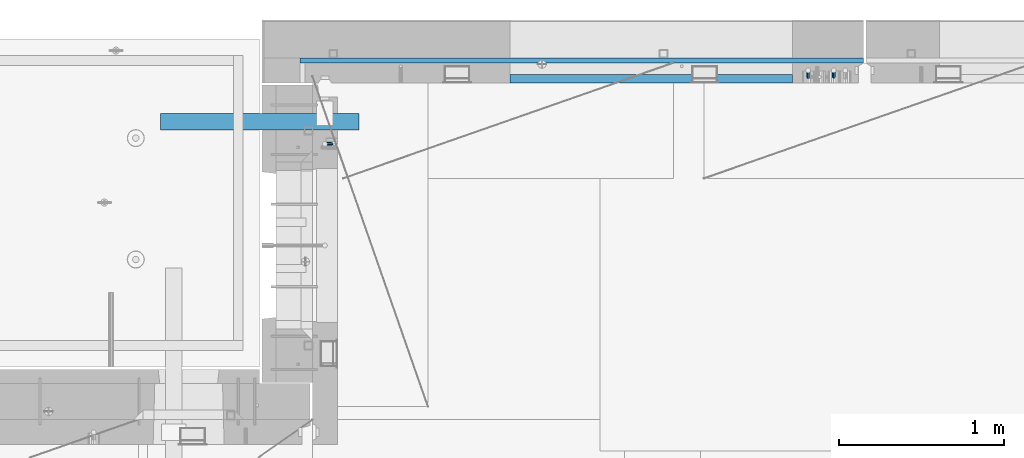
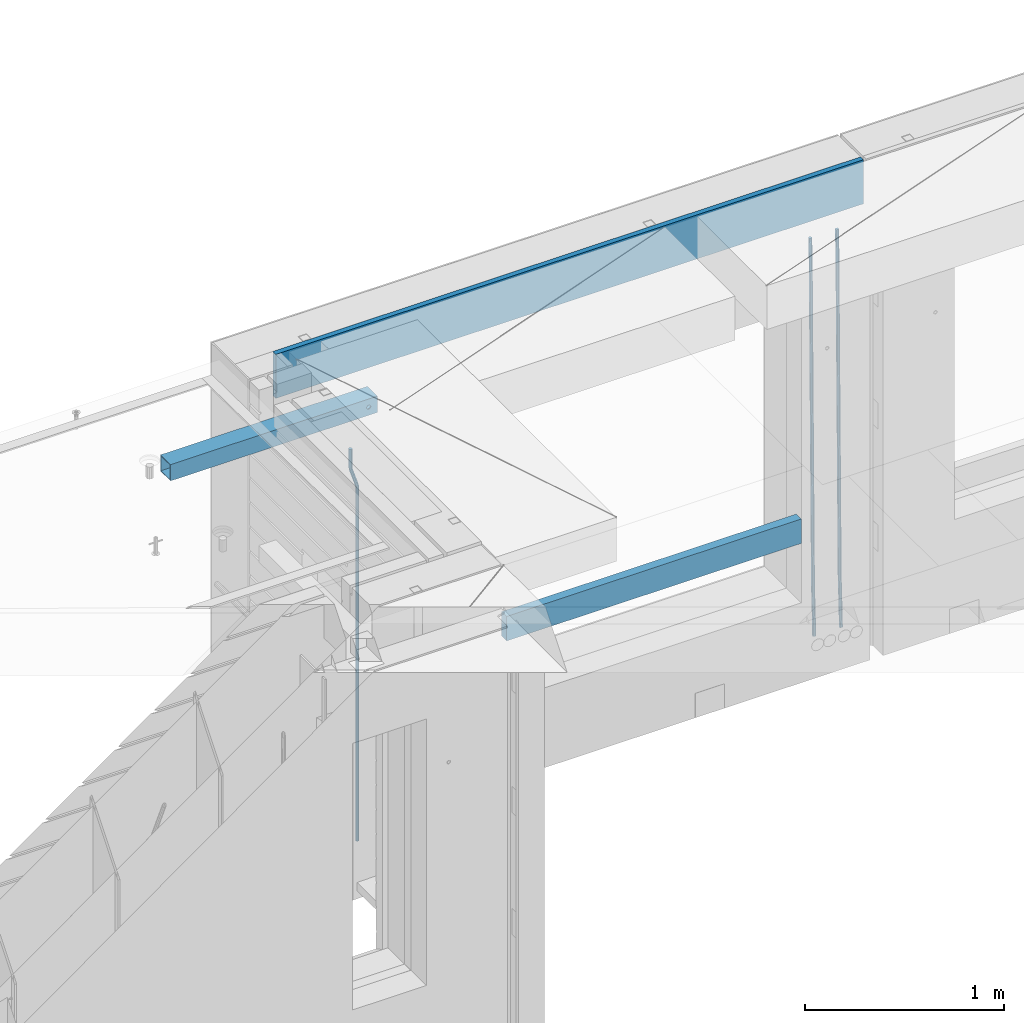
# One storey, part 117 of 349: 6 beams, 4 elements without a shape of their own.
"""IFC2X3 building model written with IfcOpenShell, lengths in millimetres."""

from ifc_helpers import new_model, si_unit, frame, origin_with_axes, place, context, subcontext, project, spatial, faceted_brep, material, type_object, element, aggregate, save


model = new_model("IFC2X3")

# Units and contexts
model_context = context("Model", 3, precision=1e-05, world=origin_with_axes())
body_context = subcontext(model_context, "Body", "Model", "MODEL_VIEW")
ifc_project = project(units=[si_unit("LENGTHUNIT", "METRE", prefix="MILLI"), si_unit("AREAUNIT", "SQUARE_METRE"), si_unit("VOLUMEUNIT", "CUBIC_METRE"), si_unit("MASSUNIT", "GRAM", prefix="KILO"), si_unit("TIMEUNIT", "SECOND"), si_unit("PLANEANGLEUNIT", "RADIAN"), si_unit("SOLIDANGLEUNIT", "STERADIAN"), si_unit("THERMODYNAMICTEMPERATUREUNIT", "DEGREE_CELSIUS"), si_unit("LUMINOUSINTENSITYUNIT", "LUMEN")], contexts=[model_context])

# Site, building, storey
site_placement = place(None, origin_with_axes())
site = spatial("IfcSite", under=ifc_project, at=site_placement, CompositionType="ELEMENT")
building_placement = place(site_placement, origin_with_axes())
building = spatial("IfcBuilding", under=site, at=building_placement, CompositionType="ELEMENT")
storey_placement = place(building_placement, origin_with_axes())
storey = spatial("IfcBuildingStorey", under=building, at=storey_placement, Name="4", CompositionType="ELEMENT", Elevation=0.0)

# Assembly, beams
assembly_1_placement = place(storey_placement, origin_with_axes())
assembly_1 = element("IfcElementAssembly", 1, at=assembly_1_placement, inside=storey, AssemblyPlace="NOTDEFINED", PredefinedType="REINFORCEMENT_UNIT")
ifc_material_1 = material()
beam_type_1 = type_object("IfcBeamType", Name="D20", PredefinedType="NOTDEFINED")
beam_1_placement = place(assembly_1_placement, frame((13990.0000000039, 22654.9999977209, 90990.0), z_axis=(-0.000205762999925498, 0.999642804629538, -0.0267249099901004), x_axis=(4.30000201928125e-08, 0.0267249099948059, 0.999642825806181)))
beam_1 = element("IfcBeam", 2, at=beam_1_placement, type_object=beam_type_1, material=ifc_material_1, Name="JM20", ObjectType="D20", context=body_context, shape_type="Brep", body=[
    faceted_brep([(0.0, -10.0, 0.0), (-4.19531716033816e-08, -7.07106781186667, -7.07106781187031), (60.4266690400545, -7.0710677960451, -7.07106780570757), (60.4266690441291, -9.99999998418934, 6.15546014159918e-09), (0.0, 0.0, -10.0), (60.426669036824, 1.58106558956206e-08, -9.99999999384454), (4.196772351861e-08, 7.07106781186303, -7.07106781186667), (60.4266690363438, 7.07106782768096, -7.07106780570757), (0.0, 10.0, 0.0), (60.4266690388904, 10.0000000158179, 6.15182216279209e-09), (4.196772351861e-08, 7.07106781185939, 7.07106781185939), (60.4266690429649, 7.07106782768096, 7.07106781802577), (0.0, 0.0, 10.0), (60.4266690461809, 1.58179318532348e-08, 10.0000000061555), (-4.19531716033816e-08, -7.07106781187031, 7.07106781185939), (60.4266690466611, -7.07106779605238, 7.07106781802213), (61.0378400410118, -7.07106779588503, -7.07106780564936), (60.991799419251, -9.99999998403655, 6.21366780251265e-09), (61.0569027789461, 1.5985278878361e-08, -9.99999999378269), (61.0378209396877, 7.07106782784831, -7.07106780564936), (60.9917724058905, 10.0000000159635, 6.21366780251265e-09), (60.9457317841297, 7.07106782781193, 7.0710678180767), (60.9266690461809, 1.59488990902901e-08, 10.0000000062028), (60.9457508854539, -7.07106779591413, 7.0710678180767), (61.6489592143771, -7.07106614513759, -7.06310863441468), (61.5568818710308, -9.9999984576425, 0.00735959856683621), (61.6870830769039, 1.71821739058942e-06, -9.99179257185824), (61.6489210170112, 7.07106947854481, -7.06310888312146), (61.556827851804, 10.0000015422847, 0.00735924683976918), (61.4647505084577, 7.07106922979438, 7.07782747982128), (61.4266266459163, 1.36643211590126e-06, 10.0065114172685), (61.464788705809, -7.07106639389531, 7.07782772852806), (176.543135720174, -7.07075579406956, -5.56673531796696), (176.451058376813, -9.99968810657447, 1.50373291501455), (176.581259582701, 0.000312069292704109, -8.49541925541052), (176.543097522794, 7.07137982961285, -5.56673556667374), (176.451004357587, 10.00031189336, 1.50373256329476), (176.35892701424, 7.07137958085514, 8.57420079627263), (176.320803151699, 0.000311717507429421, 11.5028847337162), (176.358965211621, -7.07075604281999, 8.57420104497578), (177.098753836006, -7.07075429323595, -5.55949898843028), (176.98362511232, -9.99968666800123, 1.510669025065), (177.146421932586, 0.000313595905026887, -8.48805862247536), (177.098706077581, 7.07138133041735, -5.55949936166144), (176.983557571715, 10.0003133318824, 1.51066849724157), (176.868428848029, 7.07138095712435, 8.58083651073321), (176.820760751449, 0.000313067976094317, 11.5093961447819), (176.868476606425, -7.07075466652896, 8.58083688396073), (177.654312950661, -7.07075204110879, -5.54863964998367), (177.516135294456, -9.99968450931192, 1.52107783331303), (177.711524267797, 0.000315886711177882, -8.47701274570863), (177.654255632195, 7.07138358250813, -5.54864021007961), (177.516054233929, 10.0003154905207, 1.5210770412159), (177.377876577739, 7.0713830223176, 8.59079452451624), (177.320665260588, 0.000315094497636892, 11.5191676202448), (177.377933896176, -7.07075260129932, 8.59079508461218), (299.436796249574, -7.07025836271714, -3.1681962331204), (299.298618593355, -9.99919083092027, 3.90152125031091), (299.494007566798, 0.000809565110102994, -6.09656932889993), (299.436738931283, 7.07187726089978, -3.16819679320906), (299.298537533061, 10.0008091689197, 3.90152045822106), (299.160359876842, 7.07187670072017, 10.9712379416487), (299.103148559603, 0.000808772889286047, 13.8996110374392), (299.160417195119, -7.07025892290039, 10.9712385017483), (299.98743051647, -7.07025613056248, -3.15743315966392), (299.971788958996, -9.99918809853989, 3.91467979818117), (299.993912075952, 0.000811591617093654, -6.08679785393178), (299.987423933868, 7.07187949325817, -3.1574327280432), (299.971753863239, 10.0008119014747, 3.91467990454839), (299.95611230444, 7.07187992653053, 10.9867922621015), (299.949630744944, 0.000812204350950196, 13.9161569563694), (299.956118887014, -7.07025569729012, 10.9867918304735), (300.538107039494, -7.07025785017686, -3.16575821840888), (300.644985195438, -9.99919020432935, 3.90450175465594), (300.493854948218, 0.000810030429420294, -6.09435592770024), (300.538151196495, 7.071877773491, -3.16575855385963), (300.645047642858, 10.0008097955724, 3.90450128024895), (300.751925798773, 7.07187744142357, 10.9747612533101), (300.796177890064, 0.000809560813650023, 13.9033589625978), (300.751881641787, -7.07025818224065, 10.9747615887682), (2293.36490490142, -7.07648090940347, -33.2930642912361), (2293.47178305736, -10.0054132635523, -26.2228043181785), (2293.32065281013, -0.00541302880083094, -36.2216620005347), (2293.36494905842, 7.06565471425711, -33.2930646266868), (2293.47184550477, 9.99458673634581, -26.2228047925819), (2293.57872366071, 7.06565438219332, -19.1525448195243), (2293.62297575199, -0.00541349841296324, -16.2239471102366), (2293.57867950371, -7.0764812414709, -19.1525444840736), (2294.0658245362, -7.07648309818615, -33.3036607065333), (2294.05312277409, -10.0054150789219, -26.2315929392535), (2294.10928714235, -0.00541549149056664, -36.2335844756526), (2294.15805078732, 7.06565223761572, -33.3050546393533), (2294.18355038921, 9.99458451388637, -26.2335642579346), (2294.17084862708, 7.06565253314329, -19.1614964906439), (2294.12738602093, -0.00541507354500936, -16.2315727215355), (2294.07862237596, -7.07648280265857, -19.1601025578348), (2294.76670261032, -7.08562269121467, -33.294332712383), (2294.63442802057, -10.0129954178956, -26.2238563411993), (2294.89787471293, -0.0156988342423574, -36.2230891548279), (2294.95110548967, 7.05531064255774, -33.2944998654275), (2294.89521307347, 9.98530428734011, -26.2240927312887), (2294.76293848372, 7.0579315606592, -19.1536163601049), (2294.63176638114, -0.0119922963167483, -16.2248599176673), (2294.57853560438, -7.08300177311321, -19.1534492070678), (2316.52657204497, -7.36937582653991, -33.0047303660212), (2316.39429745522, -10.2967485532172, -25.9342539948302), (2316.65774414754, -0.299451969567599, -35.9334868084661), (2316.7109749243, 6.7715575072325, -33.0048975190657), (2316.65508250811, 9.70155115201487, -25.9344903849269), (2316.52280791836, 6.7741784253376, -18.8640140137468), (2316.39163581574, -0.295745431634714, -15.9352575713092), (2316.33840503903, -7.36675490843481, -18.863846860706), (2317.16202064224, -7.37766220584308, -32.9962731735213), (2317.05438744847, -10.3053562613532, -25.9254688497131), (2317.23607125619, -0.306993473008333, -35.925789846493), (2317.23316144495, 6.76474808850253, -32.9979477328052), (2317.15499573652, 9.6950321815566, -25.9278370341635), (2317.04736254275, 6.7673381260538, -18.8570327103698), (2316.97331192881, -0.303330606784584, -15.9275160373909), (2316.97622174003, -7.37507216829545, -18.8553581510787), (2317.79752306276, -7.37578610372293, -32.9880110666527), (2317.71453320107, -10.3033876998124, -25.9168792378296), (2317.81444760226, -0.305295583297266, -35.918287695793), (2317.75539265381, 6.76628640723357, -32.9911928173897), (2317.65495180529, 9.69652304524061, -25.9213789128698), (2317.5719619436, 6.76892144914746, -18.8502470840467), (2317.55503740412, -0.301569071270933, -15.9199704549137), (2317.61409235255, -7.3731510618054, -18.847065333317), (2417.8183084176, -7.07752398473531, -31.6906369377139), (2417.73531855589, -10.0051255808248, -24.6195051088798), (2417.83523295709, -0.007033464313281, -34.6209135668432), (2417.77617800863, 7.06454852621755, -31.6938186884508), (2417.67573716014, 9.99478516423187, -24.6240047839383), (2417.59274729842, 7.06718356813872, -17.5528729551006), (2417.57582275895, -0.00330695228694822, -14.6225963259749), (2417.6348777074, -7.07488894281778, -17.5496912043673)], [[[0, 1, 2, 3]], [[1, 4, 5, 2]], [[4, 6, 7, 5]], [[6, 8, 9, 7]], [[8, 10, 11, 9]], [[10, 12, 13, 11]], [[12, 14, 15, 13]], [[14, 0, 3, 15]], [[14, 12, 10, 8, 6, 4, 1, 0]], [[3, 2, 16, 17]], [[2, 5, 18, 16]], [[5, 7, 19, 18]], [[7, 9, 20, 19]], [[9, 11, 21, 20]], [[11, 13, 22, 21]], [[13, 15, 23, 22]], [[15, 3, 17, 23]], [[17, 16, 24, 25]], [[16, 18, 26, 24]], [[18, 19, 27, 26]], [[19, 20, 28, 27]], [[20, 21, 29, 28]], [[21, 22, 30, 29]], [[22, 23, 31, 30]], [[23, 17, 25, 31]], [[25, 24, 32, 33]], [[24, 26, 34, 32]], [[26, 27, 35, 34]], [[27, 28, 36, 35]], [[28, 29, 37, 36]], [[29, 30, 38, 37]], [[30, 31, 39, 38]], [[31, 25, 33, 39]], [[33, 32, 40, 41]], [[32, 34, 42, 40]], [[34, 35, 43, 42]], [[35, 36, 44, 43]], [[36, 37, 45, 44]], [[37, 38, 46, 45]], [[38, 39, 47, 46]], [[39, 33, 41, 47]], [[41, 40, 48, 49]], [[40, 42, 50, 48]], [[42, 43, 51, 50]], [[43, 44, 52, 51]], [[44, 45, 53, 52]], [[45, 46, 54, 53]], [[46, 47, 55, 54]], [[47, 41, 49, 55]], [[49, 48, 56, 57]], [[48, 50, 58, 56]], [[50, 51, 59, 58]], [[51, 52, 60, 59]], [[52, 53, 61, 60]], [[53, 54, 62, 61]], [[54, 55, 63, 62]], [[55, 49, 57, 63]], [[57, 56, 64, 65]], [[56, 58, 66, 64]], [[58, 59, 67, 66]], [[59, 60, 68, 67]], [[60, 61, 69, 68]], [[61, 62, 70, 69]], [[62, 63, 71, 70]], [[63, 57, 65, 71]], [[65, 64, 72, 73]], [[64, 66, 74, 72]], [[66, 67, 75, 74]], [[67, 68, 76, 75]], [[68, 69, 77, 76]], [[69, 70, 78, 77]], [[70, 71, 79, 78]], [[71, 65, 73, 79]], [[73, 72, 80, 81]], [[72, 74, 82, 80]], [[74, 75, 83, 82]], [[75, 76, 84, 83]], [[76, 77, 85, 84]], [[77, 78, 86, 85]], [[78, 79, 87, 86]], [[79, 73, 81, 87]], [[81, 80, 88, 89]], [[80, 82, 90, 88]], [[82, 83, 91, 90]], [[83, 84, 92, 91]], [[84, 85, 93, 92]], [[85, 86, 94, 93]], [[86, 87, 95, 94]], [[87, 81, 89, 95]], [[89, 88, 96, 97]], [[88, 90, 98, 96]], [[90, 91, 99, 98]], [[91, 92, 100, 99]], [[92, 93, 101, 100]], [[93, 94, 102, 101]], [[94, 95, 103, 102]], [[95, 89, 97, 103]], [[97, 96, 104, 105]], [[96, 98, 106, 104]], [[98, 99, 107, 106]], [[99, 100, 108, 107]], [[100, 101, 109, 108]], [[101, 102, 110, 109]], [[102, 103, 111, 110]], [[103, 97, 105, 111]], [[105, 104, 112, 113]], [[104, 106, 114, 112]], [[106, 107, 115, 114]], [[107, 108, 116, 115]], [[108, 109, 117, 116]], [[109, 110, 118, 117]], [[110, 111, 119, 118]], [[111, 105, 113, 119]], [[113, 112, 120, 121]], [[112, 114, 122, 120]], [[114, 115, 123, 122]], [[115, 116, 124, 123]], [[116, 117, 125, 124]], [[117, 118, 126, 125]], [[118, 119, 127, 126]], [[119, 113, 121, 127]], [[121, 120, 128, 129]], [[120, 122, 130, 128]], [[122, 123, 131, 130]], [[123, 124, 132, 131]], [[124, 125, 133, 132]], [[125, 126, 134, 133]], [[126, 127, 135, 134]], [[127, 121, 129, 135]], [[130, 131, 132, 133, 134, 135, 129, 128]]]),
])
beam_2_placement = place(assembly_1_placement, frame((14145.0000000039, 22654.9999977209, 90990.0), z_axis=(-0.000205762999925498, 0.999642804629538, -0.0267249099901004), x_axis=(4.30000201928125e-08, 0.0267249099948059, 0.999642825806181)))
beam_2 = element("IfcBeam", 3, at=beam_2_placement, type_object=beam_type_1, material=ifc_material_1, Name="JM20", ObjectType="D20", context=body_context, shape_type="Brep", body=[
    faceted_brep([(0.0, -10.0, 0.0), (-4.19531716033816e-08, -7.07106781186667, -7.07106781187031), (60.4266690400545, -7.0710677960451, -7.07106780570757), (60.4266690441291, -9.99999998418934, 6.15546014159918e-09), (0.0, 0.0, -10.0), (60.426669036824, 1.58106558956206e-08, -9.99999999384454), (4.196772351861e-08, 7.07106781186303, -7.07106781186667), (60.4266690363438, 7.07106782768096, -7.07106780570757), (0.0, 10.0, 0.0), (60.4266690388904, 10.0000000158179, 6.15182216279209e-09), (4.196772351861e-08, 7.07106781185939, 7.07106781185939), (60.4266690429649, 7.07106782768096, 7.07106781802577), (0.0, 0.0, 10.0), (60.4266690461809, 1.58179318532348e-08, 10.0000000061555), (-4.19531716033816e-08, -7.07106781187031, 7.07106781185939), (60.4266690466611, -7.07106779605238, 7.07106781802213), (61.0378400410118, -7.07106779588503, -7.07106780564936), (60.991799419251, -9.99999998403655, 6.21366780251265e-09), (61.0569027789461, 1.5985278878361e-08, -9.99999999378269), (61.0378209396877, 7.07106782784831, -7.07106780564936), (60.9917724058905, 10.0000000159635, 6.21366780251265e-09), (60.9457317841297, 7.07106782781193, 7.0710678180767), (60.9266690461809, 1.59488990902901e-08, 10.0000000062028), (60.9457508854539, -7.07106779591413, 7.0710678180767), (61.6489592143771, -7.07106614513759, -7.06310863441468), (61.5568818710308, -9.9999984576425, 0.00735959856683621), (61.6870830769039, 1.71821739058942e-06, -9.99179257185824), (61.6489210170112, 7.07106947854481, -7.06310888312146), (61.556827851804, 10.0000015422847, 0.00735924683976918), (61.4647505084577, 7.07106922979438, 7.07782747982128), (61.4266266459163, 1.36643211590126e-06, 10.0065114172685), (61.464788705809, -7.07106639389531, 7.07782772852806), (176.543135720174, -7.07075579406956, -5.56673531796696), (176.451058376813, -9.99968810657447, 1.50373291501455), (176.581259582701, 0.000312069292704109, -8.49541925541052), (176.543097522794, 7.07137982961285, -5.56673556667374), (176.451004357587, 10.00031189336, 1.50373256329476), (176.35892701424, 7.07137958085514, 8.57420079627263), (176.320803151699, 0.000311717507429421, 11.5028847337162), (176.358965211621, -7.07075604281999, 8.57420104497578), (177.098753836006, -7.07075429323595, -5.55949898843028), (176.98362511232, -9.99968666800123, 1.510669025065), (177.146421932586, 0.000313595905026887, -8.48805862247536), (177.098706077581, 7.07138133041735, -5.55949936166144), (176.983557571715, 10.0003133318824, 1.51066849724157), (176.868428848029, 7.07138095712435, 8.58083651073321), (176.820760751449, 0.000313067976094317, 11.5093961447819), (176.868476606425, -7.07075466652896, 8.58083688396073), (177.654312950661, -7.07075204110879, -5.54863964998367), (177.516135294456, -9.99968450931192, 1.52107783331303), (177.711524267797, 0.000315886711177882, -8.47701274570863), (177.654255632195, 7.07138358250813, -5.54864021007961), (177.516054233929, 10.0003154905207, 1.5210770412159), (177.377876577739, 7.0713830223176, 8.59079452451624), (177.320665260588, 0.000315094497636892, 11.5191676202448), (177.377933896176, -7.07075260129932, 8.59079508461218), (299.436796249574, -7.07025836271714, -3.1681962331204), (299.298618593355, -9.99919083092027, 3.90152125031091), (299.494007566798, 0.000809565110102994, -6.09656932889993), (299.436738931283, 7.07187726089978, -3.16819679320906), (299.298537533061, 10.0008091689197, 3.90152045822106), (299.160359876842, 7.07187670072017, 10.9712379416487), (299.103148559603, 0.000808772889286047, 13.8996110374392), (299.160417195119, -7.07025892290039, 10.9712385017483), (299.98743051647, -7.07025613056248, -3.15743315966392), (299.971788958996, -9.99918809853989, 3.91467979818117), (299.993912075952, 0.000811591617093654, -6.08679785393178), (299.987423933868, 7.07187949325817, -3.1574327280432), (299.971753863239, 10.0008119014747, 3.91467990454839), (299.95611230444, 7.07187992653053, 10.9867922621015), (299.949630744944, 0.000812204350950196, 13.9161569563694), (299.956118887014, -7.07025569729012, 10.9867918304735), (300.538107039494, -7.07025785017686, -3.16575821840888), (300.644985195438, -9.99919020432935, 3.90450175465594), (300.493854948218, 0.000810030429420294, -6.09435592770024), (300.538151196495, 7.071877773491, -3.16575855385963), (300.645047642858, 10.0008097955724, 3.90450128024895), (300.751925798773, 7.07187744142357, 10.9747612533101), (300.796177890064, 0.000809560813650023, 13.9033589625978), (300.751881641787, -7.07025818224065, 10.9747615887682), (2293.36490490142, -7.07648090940347, -33.2930642912361), (2293.47178305736, -10.0054132635523, -26.2228043181785), (2293.32065281013, -0.00541302880083094, -36.2216620005347), (2293.36494905842, 7.06565471425711, -33.2930646266868), (2293.47184550477, 9.99458673634581, -26.2228047925819), (2293.57872366071, 7.06565438219332, -19.1525448195243), (2293.62297575199, -0.00541349841296324, -16.2239471102366), (2293.57867950371, -7.0764812414709, -19.1525444840736), (2294.0658245362, -7.07648309818615, -33.3036607065333), (2294.05312277409, -10.0054150789219, -26.2315929392535), (2294.10928714235, -0.00541549149056664, -36.2335844756526), (2294.15805078732, 7.06565223761572, -33.3050546393533), (2294.18355038921, 9.99458451388637, -26.2335642579346), (2294.17084862708, 7.06565253314329, -19.1614964906439), (2294.12738602093, -0.00541507354500936, -16.2315727215355), (2294.07862237596, -7.07648280265857, -19.1601025578348), (2294.76670261032, -7.08562269121467, -33.294332712383), (2294.63442802057, -10.0129954178956, -26.2238563411993), (2294.89787471293, -0.0156988342423574, -36.2230891548279), (2294.95110548967, 7.05531064255774, -33.2944998654275), (2294.89521307347, 9.98530428734011, -26.2240927312887), (2294.76293848372, 7.0579315606592, -19.1536163601049), (2294.63176638114, -0.0119922963167483, -16.2248599176673), (2294.57853560438, -7.08300177311321, -19.1534492070678), (2316.52657204497, -7.36937582653991, -33.0047303660212), (2316.39429745522, -10.2967485532172, -25.9342539948302), (2316.65774414754, -0.299451969567599, -35.9334868084661), (2316.7109749243, 6.7715575072325, -33.0048975190657), (2316.65508250811, 9.70155115201487, -25.9344903849269), (2316.52280791836, 6.7741784253376, -18.8640140137468), (2316.39163581574, -0.295745431634714, -15.9352575713092), (2316.33840503903, -7.36675490843481, -18.863846860706), (2317.16202064224, -7.37766220584308, -32.9962731735213), (2317.05438744847, -10.3053562613532, -25.9254688497131), (2317.23607125619, -0.306993473008333, -35.925789846493), (2317.23316144495, 6.76474808850253, -32.9979477328052), (2317.15499573652, 9.6950321815566, -25.9278370341635), (2317.04736254275, 6.7673381260538, -18.8570327103698), (2316.97331192881, -0.303330606784584, -15.9275160373909), (2316.97622174003, -7.37507216829545, -18.8553581510787), (2317.79752306276, -7.37578610372293, -32.9880110666527), (2317.71453320107, -10.3033876998124, -25.9168792378296), (2317.81444760226, -0.305295583297266, -35.918287695793), (2317.75539265381, 6.76628640723357, -32.9911928173897), (2317.65495180529, 9.69652304524061, -25.9213789128698), (2317.5719619436, 6.76892144914746, -18.8502470840467), (2317.55503740412, -0.301569071270933, -15.9199704549137), (2317.61409235255, -7.3731510618054, -18.847065333317), (2417.8183084176, -7.07752398473531, -31.6906369377139), (2417.73531855589, -10.0051255808248, -24.6195051088798), (2417.83523295709, -0.007033464313281, -34.6209135668432), (2417.77617800863, 7.06454852621755, -31.6938186884508), (2417.67573716014, 9.99478516423187, -24.6240047839383), (2417.59274729842, 7.06718356813872, -17.5528729551006), (2417.57582275895, -0.00330695228694822, -14.6225963259749), (2417.6348777074, -7.07488894281778, -17.5496912043673)], [[[0, 1, 2, 3]], [[1, 4, 5, 2]], [[4, 6, 7, 5]], [[6, 8, 9, 7]], [[8, 10, 11, 9]], [[10, 12, 13, 11]], [[12, 14, 15, 13]], [[14, 0, 3, 15]], [[14, 12, 10, 8, 6, 4, 1, 0]], [[3, 2, 16, 17]], [[2, 5, 18, 16]], [[5, 7, 19, 18]], [[7, 9, 20, 19]], [[9, 11, 21, 20]], [[11, 13, 22, 21]], [[13, 15, 23, 22]], [[15, 3, 17, 23]], [[17, 16, 24, 25]], [[16, 18, 26, 24]], [[18, 19, 27, 26]], [[19, 20, 28, 27]], [[20, 21, 29, 28]], [[21, 22, 30, 29]], [[22, 23, 31, 30]], [[23, 17, 25, 31]], [[25, 24, 32, 33]], [[24, 26, 34, 32]], [[26, 27, 35, 34]], [[27, 28, 36, 35]], [[28, 29, 37, 36]], [[29, 30, 38, 37]], [[30, 31, 39, 38]], [[31, 25, 33, 39]], [[33, 32, 40, 41]], [[32, 34, 42, 40]], [[34, 35, 43, 42]], [[35, 36, 44, 43]], [[36, 37, 45, 44]], [[37, 38, 46, 45]], [[38, 39, 47, 46]], [[39, 33, 41, 47]], [[41, 40, 48, 49]], [[40, 42, 50, 48]], [[42, 43, 51, 50]], [[43, 44, 52, 51]], [[44, 45, 53, 52]], [[45, 46, 54, 53]], [[46, 47, 55, 54]], [[47, 41, 49, 55]], [[49, 48, 56, 57]], [[48, 50, 58, 56]], [[50, 51, 59, 58]], [[51, 52, 60, 59]], [[52, 53, 61, 60]], [[53, 54, 62, 61]], [[54, 55, 63, 62]], [[55, 49, 57, 63]], [[57, 56, 64, 65]], [[56, 58, 66, 64]], [[58, 59, 67, 66]], [[59, 60, 68, 67]], [[60, 61, 69, 68]], [[61, 62, 70, 69]], [[62, 63, 71, 70]], [[63, 57, 65, 71]], [[65, 64, 72, 73]], [[64, 66, 74, 72]], [[66, 67, 75, 74]], [[67, 68, 76, 75]], [[68, 69, 77, 76]], [[69, 70, 78, 77]], [[70, 71, 79, 78]], [[71, 65, 73, 79]], [[73, 72, 80, 81]], [[72, 74, 82, 80]], [[74, 75, 83, 82]], [[75, 76, 84, 83]], [[76, 77, 85, 84]], [[77, 78, 86, 85]], [[78, 79, 87, 86]], [[79, 73, 81, 87]], [[81, 80, 88, 89]], [[80, 82, 90, 88]], [[82, 83, 91, 90]], [[83, 84, 92, 91]], [[84, 85, 93, 92]], [[85, 86, 94, 93]], [[86, 87, 95, 94]], [[87, 81, 89, 95]], [[89, 88, 96, 97]], [[88, 90, 98, 96]], [[90, 91, 99, 98]], [[91, 92, 100, 99]], [[92, 93, 101, 100]], [[93, 94, 102, 101]], [[94, 95, 103, 102]], [[95, 89, 97, 103]], [[97, 96, 104, 105]], [[96, 98, 106, 104]], [[98, 99, 107, 106]], [[99, 100, 108, 107]], [[100, 101, 109, 108]], [[101, 102, 110, 109]], [[102, 103, 111, 110]], [[103, 97, 105, 111]], [[105, 104, 112, 113]], [[104, 106, 114, 112]], [[106, 107, 115, 114]], [[107, 108, 116, 115]], [[108, 109, 117, 116]], [[109, 110, 118, 117]], [[110, 111, 119, 118]], [[111, 105, 113, 119]], [[113, 112, 120, 121]], [[112, 114, 122, 120]], [[114, 115, 123, 122]], [[115, 116, 124, 123]], [[116, 117, 125, 124]], [[117, 118, 126, 125]], [[118, 119, 127, 126]], [[119, 113, 121, 127]], [[121, 120, 128, 129]], [[120, 122, 130, 128]], [[122, 123, 131, 130]], [[123, 124, 132, 131]], [[124, 125, 133, 132]], [[125, 126, 134, 133]], [[126, 127, 135, 134]], [[127, 121, 129, 135]], [[130, 131, 132, 133, 134, 135, 129, 128]]]),
])

# Assembly, beam
assembly_2_placement = place(storey_placement, origin_with_axes())
assembly_2 = element("IfcElementAssembly", 4, at=assembly_2_placement, inside=storey, AssemblyPlace="NOTDEFINED", PredefinedType="REINFORCEMENT_UNIT")
beam_3_placement = place(assembly_2_placement, frame((11065.0, 22249.9963332647, 93407.5), z_axis=(0.999999913638316, -0.000415599999849952, 0.0), x_axis=(0.0, 0.0, -1.0)))
beam_3 = element("IfcBeam", 5, at=beam_3_placement, type_object=beam_type_1, material=ifc_material_1, Name="JM20", ObjectType="D20", context=body_context, shape_type="Brep", body=[
    faceted_brep([(0.0, -10.0, 0.0), (-4.19531716033816e-08, -7.07106781186667, -7.07106781187031), (113.248091332178, -7.0710684840451, -7.0710678117357), (113.248091314759, -10.0000006713562, -2.51020537689328e-10), (0.0, 0.0, -10.0), (113.248091374131, -6.72178430249915e-07, -9.99999999986903), (4.196772351861e-08, 7.07106781186303, -7.07106781186667), (113.248091416113, 7.07106713968824, -7.07106781173934), (0.0, 10.0, 0.0), (113.248091433488, 9.99999932782521, 1.30967237055302e-10), (4.196772351861e-08, 7.07106781185939, 7.07106781185939), (113.248091416113, 7.0710671396846, 7.071067811994), (0.0, 0.0, 10.0), (113.248091374131, -6.72174792271107e-07, 10.0000000001273), (-4.19531716033816e-08, -7.07106781187031, 7.07106781185939), (113.248091332178, -7.0710684840451, 7.071067811994), (130.699843527167, -7.06993249763036, -4.33745683788584), (128.538066582521, -9.99900540317321, 2.39499413731755), (131.594536475241, 0.00119355250353692, -7.12624594330919), (130.698046432328, 7.07220300913468, -4.33773834422391), (128.535525107087, 10.0009944322555, 2.39459602660281), (126.373748162892, 7.07192152754578, 9.1270470011732), (125.479055214906, 0.000795477419160306, 11.9158361066184), (126.37554525779, -7.07021397921199, 9.12732850753673), (240.336258550378, -7.05529970173666, 30.8729495437874), (238.174481606227, -9.98437260450009, 37.6054005176375), (241.230951498423, 0.0158263482953771, 28.0841604381058), (240.334461455612, 7.0868358050102, 30.8726680369582), (238.171940130502, 10.0156272283348, 37.6050024077231), (236.010163186409, 7.08655432384694, 44.3374533824244), (235.115470238379, 0.0154282738185429, 47.1262424881097), (236.011960281176, -7.05558118289991, 44.3377348892536), (253.461915329972, -7.05444528127919, 32.9289287376414), (253.46191532613, -9.98337746617108, 39.9999965521893), (253.461915339081, 0.0166225284556276, 29.9999965443676), (253.461915348205, 7.08769034247234, 32.9289287273205), (253.461915352003, 10.0166225357716, 39.9999965370152), (253.461915348293, 7.08769035281148, 47.0710643509774), (253.461915339183, 0.0166225430875784, 49.999996544273), (253.46191533003, -7.05444527093641, 47.0710643613093), (2417.50000002384, -7.0544364694706, 32.9289287374122), (2417.5000000337, -9.98336865393321, 39.9999965507959), (2417.49999999997, 0.0166313408753922, 29.9999965456082), (2417.49999997609, 7.08769915426274, 32.9289287300708), (2417.4999999662, 10.0166313460668, 39.9999965404204), (2417.49999997608, 7.08769916160054, 47.0710643538114), (2417.49999999994, 0.0166313512581837, 49.9999965456154), (2417.50000002382, -7.05443646212916, 47.0710643611455)], [[[0, 1, 2, 3]], [[1, 4, 5, 2]], [[4, 6, 7, 5]], [[6, 8, 9, 7]], [[8, 10, 11, 9]], [[10, 12, 13, 11]], [[12, 14, 15, 13]], [[14, 0, 3, 15]], [[14, 12, 10, 8, 6, 4, 1, 0]], [[3, 2, 16, 17]], [[2, 5, 18, 16]], [[5, 7, 19, 18]], [[7, 9, 20, 19]], [[9, 11, 21, 20]], [[11, 13, 22, 21]], [[13, 15, 23, 22]], [[15, 3, 17, 23]], [[17, 16, 24, 25]], [[16, 18, 26, 24]], [[18, 19, 27, 26]], [[19, 20, 28, 27]], [[20, 21, 29, 28]], [[21, 22, 30, 29]], [[22, 23, 31, 30]], [[23, 17, 25, 31]], [[25, 24, 32, 33]], [[24, 26, 34, 32]], [[26, 27, 35, 34]], [[27, 28, 36, 35]], [[28, 29, 37, 36]], [[29, 30, 38, 37]], [[30, 31, 39, 38]], [[31, 25, 33, 39]], [[33, 32, 40, 41]], [[32, 34, 42, 40]], [[34, 35, 43, 42]], [[35, 36, 44, 43]], [[36, 37, 45, 44]], [[37, 38, 46, 45]], [[38, 39, 47, 46]], [[39, 33, 41, 47]], [[42, 43, 44, 45, 46, 47, 41, 40]]]),
])
aggregate(assembly_2, [beam_3])

# Beam
ifc_material_2 = material(Name="TIMBER/T24")
beam_type_2 = type_object("IfcBeamType", PredefinedType="NOTDEFINED")
beam_4_placement = place(assembly_1_placement, frame((13895.0002980493, 22644.9998418812, 91685.0), z_axis=(0.0, 0.0, 1.0), x_axis=(-1.0, 3.00000001838171e-08, 0.0)))
beam_4 = element("IfcBeam", 6, at=beam_4_placement, type_object=beam_type_2, material=ifc_material_2, context=body_context, shape_type="Brep", body=[
    faceted_brep([(-3.63797880709171e-12, 24.9999999999964, -75.0), (-3.63797880709171e-12, 24.9999999999964, 75.0), (1710.0, 25.0, 75.0), (1710.0, 25.0, -75.0), (0.0, -25.0000000000073, 75.0), (1709.99999999999, -25.0, 75.0), (0.0, -25.0000000000073, -75.0), (1709.99999999999, -25.0, -75.0)], [[[0, 1, 2, 3]], [[1, 4, 5, 2]], [[4, 6, 7, 5]], [[6, 0, 3, 7]], [[5, 7, 3, 2]], [[6, 4, 1, 0]]]),
])

# Assemblies, beam
assembly_3_placement = place(storey_placement, origin_with_axes())
assembly_3 = element("IfcElementAssembly", 7, at=assembly_3_placement, inside=storey, AssemblyPlace="NOTDEFINED", PredefinedType="REINFORCEMENT_UNIT")
assembly_4_placement = place(assembly_3_placement, origin_with_axes())
assembly_4 = element("IfcElementAssembly", 8, at=assembly_4_placement, AssemblyPlace="NOTDEFINED", PredefinedType="NOTDEFINED")
aggregate(assembly_3, [assembly_4])
ifc_material_3 = material(Name="Undefined/350")
beam_type_3 = type_object("IfcBeamType", Name="100X100X5", PredefinedType="NOTDEFINED")
beam_5_placement = place(assembly_4_placement, frame((10069.9865573969, 22385.0401432011, 93555.0), z_axis=(0.0, 0.0, 1.0), x_axis=(0.999999999752625, -2.22429999942101e-05, 0.0)))
beam_5 = element("IfcBeam", 9, at=beam_5_placement, type_object=beam_type_3, material=ifc_material_3, ObjectType="100X100X5", context=body_context, shape_type="Brep", body=[
    faceted_brep([(1156.2510802317, 44.9999999999982, 10.8253175473074), (1156.25107855315, 50.0256005946221, 10.8253175473074), (1160.82639610046, 50.0256021227788, 6.25), (1160.82639777901, 44.9999999999982, 6.25), (1150.00108023171, 44.9999999999982, 12.5), (1150.00107855316, 50.0255985071226, 12.5), (1143.75108023171, 44.9999999999982, 10.8253175473074), (1143.75107855316, 50.0255964196231, 10.8253175473074), (1139.1757626844, 44.9999999999982, 6.25), (1139.17576100585, 50.0255948914664, 6.25), (1137.5010802317, 44.9999999999982, 0.0), (1137.50107855316, 50.0255943321226, 0.0), (1139.1757626844, 44.9999999999982, -6.25), (1139.17576100585, 50.0255948914664, -6.25), (1143.75108023171, 44.9999999999982, -10.8253175473074), (1143.75107855316, 50.0255964196231, -10.8253175473074), (1150.00108023171, 44.9999999999982, -12.5), (1150.00107855316, 50.0255985071226, -12.5), (1156.2510802317, 44.9999999999982, -10.8253175473074), (1156.25107855315, 50.0256005946221, -10.8253175473074), (1160.82639777901, 44.9999999999982, -6.25), (1160.82639610046, 50.0256021227788, -6.25), (1162.50108023171, 44.9999999999982, 0.0), (1162.50107855316, 50.0256026821226, 0.0), (1156.25111195316, -49.9743994042774, 10.8253175473074), (1156.25111029171, -44.9999999999991, 10.8253175473074), (1160.82642783901, -44.9999999999991, 6.25), (1160.82642950046, -49.9743978761207, 6.25), (1150.00111195316, -49.9744014917787, 12.5), (1150.00111029171, -44.9999999999991, 12.5), (1143.75111195316, -49.9744035792783, 10.8253175473074), (1143.75111029171, -44.9999999999991, 10.8253175473074), (1139.17579440585, -49.9744051074349, 6.25), (1139.1757927444, -44.9999999999991, 6.25), (1137.50111195316, -49.9744056667778, 0.0), (1137.50111029171, -44.9999999999991, 0.0), (1139.17579440585, -49.9744051074349, -6.25), (1139.1757927444, -44.9999999999991, -6.25), (1143.75111195316, -49.9744035792783, -10.8253175473074), (1143.75111029171, -44.9999999999991, -10.8253175473074), (1150.00111195316, -49.9744014917787, -12.5), (1150.00111029171, -44.9999999999991, -12.5), (1156.25111195316, -49.9743994042774, -10.8253175473074), (1156.25111029171, -44.9999999999991, -10.8253175473074), (1160.82642950046, -49.9743978761207, -6.25), (1160.82642783901, -44.9999999999991, -6.25), (1162.50111195316, -49.9743973167779, 0.0), (1162.50111029171, -44.9999999999991, 0.0), (1.81898940354586e-12, -50.0000000000009, -50.0), (1.81898940354586e-12, 49.9999999999991, -50.0), (1200.00449189278, 49.9999999999982, -50.0), (1200.00449189278, -50.0000000000009, -50.0), (1.81898940354586e-12, 49.9999999999991, 50.0), (1.81898940354586e-12, -50.0000000000009, 50.0), (1200.00449189278, -50.0000000000009, 50.0), (1200.00449189278, 49.9999999999982, 50.0), (0.0, 44.9999999999991, 45.0), (1.81898940354586e-12, -45.0000000000009, 45.0), (1.81898940354586e-12, -45.0000000000009, -45.0), (0.0, 44.9999999999991, -45.0), (1200.00449189278, 44.9999999999982, -45.0), (1200.00449189278, 44.9999999999982, 45.0), (1200.00449189278, -45.0000000000009, 45.0), (1200.00449189278, -45.0000000000009, -45.0)], [[[0, 1, 2, 3]], [[4, 5, 1, 0]], [[6, 7, 5, 4]], [[8, 9, 7, 6]], [[10, 11, 9, 8]], [[12, 13, 11, 10]], [[14, 15, 13, 12]], [[16, 17, 15, 14]], [[18, 19, 17, 16]], [[20, 21, 19, 18]], [[22, 23, 21, 20]], [[3, 2, 23, 22]], [[24, 25, 26, 27]], [[28, 29, 25, 24]], [[30, 31, 29, 28]], [[32, 33, 31, 30]], [[34, 35, 33, 32]], [[36, 37, 35, 34]], [[38, 39, 37, 36]], [[40, 41, 39, 38]], [[42, 43, 41, 40]], [[44, 45, 43, 42]], [[46, 47, 45, 44]], [[27, 26, 47, 46]], [[48, 49, 50, 51]], [[52, 53, 54, 55]], [[49, 52, 55, 50], [1, 5, 7, 9, 11, 13, 15, 17, 19, 21, 23, 2]], [[48, 53, 52, 49], [56, 57, 58, 59]], [[56, 59, 60, 61], [18, 16, 14, 12, 10, 8, 6, 4, 0, 3, 22, 20]], [[57, 56, 61, 62]], [[58, 57, 62, 63], [25, 29, 31, 33, 35, 37, 39, 41, 43, 45, 47, 26]], [[59, 58, 63, 60]], [[54, 51, 50, 55], [62, 61, 60, 63]], [[53, 48, 51, 54], [42, 40, 38, 36, 34, 32, 30, 28, 24, 27, 46, 44]]]),
])
aggregate(assembly_4, [beam_5])

# Beam
ifc_material_4 = material(Name="CONCRETE/C25/30")
beam_type_4 = type_object("IfcBeamType", Name="270X30", PredefinedType="NOTDEFINED")
beam_6_placement = place(assembly_1_placement, frame((14325.0, 22755.0, 93605.0), z_axis=(0.0, 0.0, 1.0), x_axis=(-1.0, 3.00000001838171e-08, 0.0)))
beam_6 = element("IfcBeam", 10, at=beam_6_placement, type_object=beam_type_4, material=ifc_material_4, ObjectType="270X30", context=body_context, shape_type="Brep", body=[
    faceted_brep([(0.0, 15.0, -135.0), (0.0, 15.0, 135.0), (3410.00000000003, 15.0, 135.0), (3410.00000000003, 15.0, -135.0), (0.0, -15.0, 135.0), (3410.00000000003, -15.0, 135.0), (0.0, -15.0, -135.0), (3410.00000000003, -15.0, -135.0)], [[[0, 1, 2, 3]], [[1, 4, 5, 2]], [[4, 6, 7, 5]], [[6, 0, 3, 7]], [[5, 7, 3, 2]], [[6, 4, 1, 0]]]),
])

aggregate(assembly_1, [beam_1, beam_2, beam_6, beam_4])

save(model, "model.ifc")
